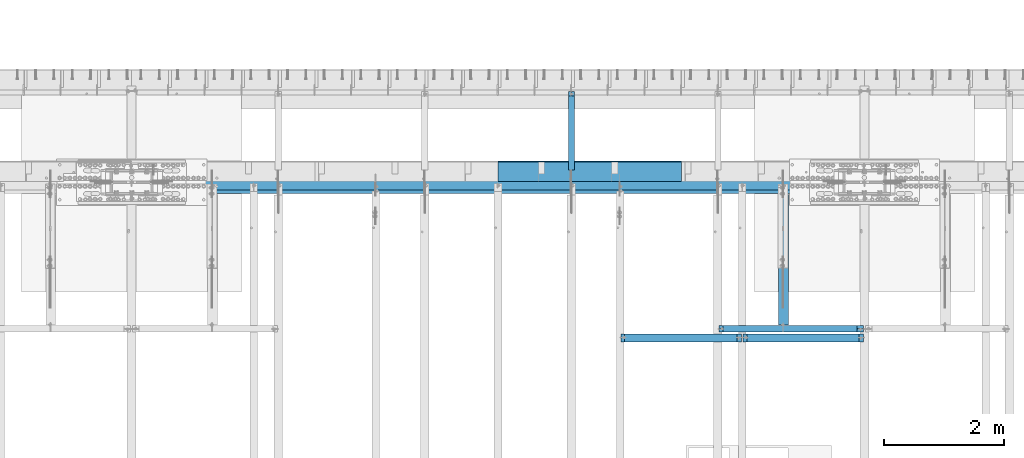
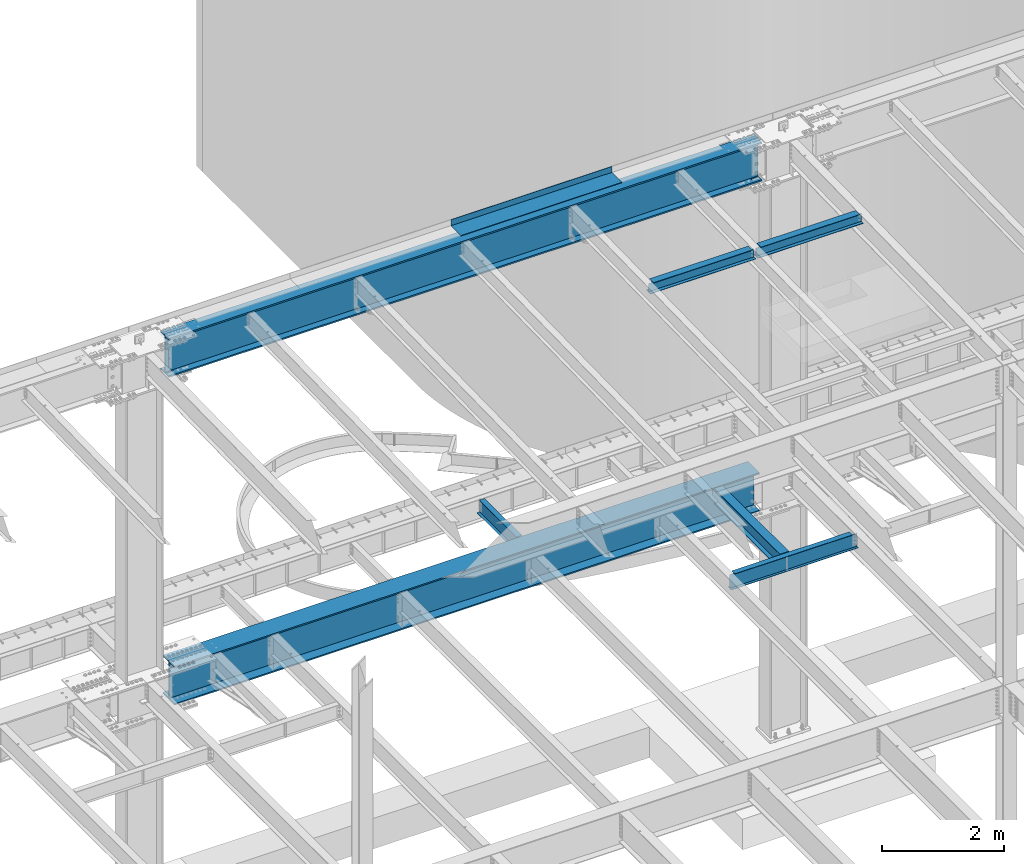
# One storey, part 1135 of 1763: 8 beams, 7 elements without a shape of their own.
"""IFC2X3 building model written with IfcOpenShell, lengths in millimetres."""

from ifc_helpers import new_model, si_unit, frame, origin_with_axes, place, context, subcontext, project, spatial, faceted_brep, material, type_object, element, aggregate, save


model = new_model("IFC2X3")

# Units and contexts
model_context = context("Model", 3, precision=1e-05, world=origin_with_axes())
body_context = subcontext(model_context, "Body", "Model", "MODEL_VIEW")
ifc_project = project(units=[si_unit("LENGTHUNIT", "METRE", prefix="MILLI"), si_unit("AREAUNIT", "SQUARE_METRE"), si_unit("VOLUMEUNIT", "CUBIC_METRE"), si_unit("MASSUNIT", "GRAM", prefix="KILO"), si_unit("TIMEUNIT", "SECOND"), si_unit("PLANEANGLEUNIT", "RADIAN"), si_unit("SOLIDANGLEUNIT", "STERADIAN"), si_unit("THERMODYNAMICTEMPERATUREUNIT", "DEGREE_CELSIUS"), si_unit("LUMINOUSINTENSITYUNIT", "LUMEN")], contexts=[model_context])

# Site, building, storey
site_placement = place(None, origin_with_axes())
site = spatial("IfcSite", under=ifc_project, at=site_placement, CompositionType="ELEMENT")
building_placement = place(site_placement, origin_with_axes())
building = spatial("IfcBuilding", under=site, at=building_placement, Name="Undefined", CompositionType="ELEMENT")
storey_placement = place(building_placement, origin_with_axes())
storey = spatial("IfcBuildingStorey", under=building, at=storey_placement, Name="Undefined", CompositionType="ELEMENT", Elevation=0.0)

# Assembly, beam
assembly_1_placement = place(storey_placement, origin_with_axes())
assembly_1 = element("IfcElementAssembly", 1, at=assembly_1_placement, inside=storey, Name="BEAM", AssemblyPlace="NOTDEFINED", PredefinedType="RIGID_FRAME")
ifc_material_1 = material(Name="STEEL/A992")
beam_type_1 = type_object("IfcBeamType", Name="W8X18", PredefinedType="NOTDEFINED")
beam_1_placement = place(assembly_1_placement, frame((-53466.5223188412, 49529.603125, 11592.1111170495), z_axis=(0.0, 0.0, 1.0), x_axis=(1.0, 0.0, 0.0)))
beam_1 = element("IfcBeam", 2, at=beam_1_placement, type_object=beam_type_1, material=ifc_material_1, Name="BEAM", ObjectType="W8X18", context=body_context, shape_type="Brep", body=[
    faceted_brep([(1947.72688668019, -3.17500000383734, 68.5472454981009), (1947.7268866802, 3.1749999961612, 68.5472454981009), (1946.86590192084, 3.17499999616848, 69.8358002505338), (1946.86590177228, -3.17500000383006, 69.8358004728379), (1951.84706314834, -3.17500000384462, 65.7942315976234), (1951.84706314836, 3.17499999615393, 65.7942315976234), (1956.70714266639, -3.17500000385189, 64.8275016750358), (1956.7071426664, 3.17499999614665, 64.8275016750358), (2015.44464294919, -3.17500000397558, 64.8275016750358), (2015.44464276504, 3.17499999602296, 64.8275016750358), (1946.13938981476, -3.17500000383006, 70.3212402430472), (1946.13938963061, 3.17499999616848, 70.3212402430472), (1943.38637573014, 3.17499999617576, 74.4414167112009), (1943.38637591428, -3.17500000383006, 74.4414167112009), (1942.41964580755, 3.17499999617576, 79.3014962292473), (1942.41964599169, -3.17500000382279, 79.3014962292473), (76.1999968561649, 3.17499999984284, 95.25), (76.1999950146637, 66.6749999998428, 95.25), (1942.41964396604, 66.6749999961758, 95.25), (1942.41964580755, 3.17499999617576, 95.25), (76.1999988818134, -66.6750000001557, 103.1875), (76.1999988818134, -66.6750000001557, 95.25), (1942.41964783319, -66.6750000038228, 95.25), (1942.41964783319, -66.6750000038228, 103.1875), (76.1999950146637, 66.6749999998428, 103.1875), (1942.41964396604, 66.6749999961758, 103.1875), (1942.41964599169, -3.17500000382279, 95.25), (76.1999970403122, -3.17500000015571, 95.25), (76.1999968561649, 3.17499999984284, 79.3014961863064), (76.1999970403122, -3.17500000015571, 79.3014961863064), (75.2332669335738, 3.17499999985012, 74.44141666826), (75.233267117721, -3.17500000014843, 74.44141666826), (72.4802530330999, 3.17499999985012, 70.3212402001063), (72.4802532172471, -3.17500000014843, 70.3212402001063), (71.7537410457226, 3.17499999985739, 69.83580040995), (71.7537408971693, -3.17500000014115, 69.8358001876459), (70.8927561769378, 3.17499999985739, 68.5472454937626), (70.8927561769233, -3.17500000014115, 68.5472454937626), (66.7725797087842, 3.17499999986467, 65.7942315932851), (66.7725797087696, -3.17500000013388, 65.7942315932851), (61.912500190745, 3.17499999987194, 64.8275016706975), (61.9125001907232, -3.1750000001266, 64.8275016706975), (15.8749999079228, 3.17499999996653, 64.8275016706975), (15.87500009207, -3.17500000003201, 64.8275016706975), (15.8749999079228, 3.17499999996653, -95.25), (15.8749980664215, 66.6749999999665, -95.25), (15.8749980664215, 66.6749999999665, -103.1875), (15.8750019335712, -66.675000000032, -103.1875), (15.8750019335712, -66.675000000032, -95.25), (15.87500009207, -3.17500000003201, -95.25), (2015.44464276504, 3.17499999602296, -95.25), (2015.44464092355, 66.674999996023, -95.25), (2015.44464092355, 66.674999996023, -103.1875), (2015.4446447907, -66.6750000039756, -103.1875), (2015.4446447907, -66.6750000039756, -95.25), (2015.44464294919, -3.17500000397558, -95.25)], [[[0, 1, 2, 3]], [[4, 5, 1, 0]], [[6, 7, 5, 4]], [[8, 9, 7, 6]], [[10, 11, 12, 13]], [[13, 12, 14, 15]], [[16, 17, 18, 19]], [[20, 21, 22, 23]], [[24, 20, 23, 25]], [[17, 24, 25, 18]], [[23, 22, 26, 15, 14, 19, 18, 25]], [[21, 27, 26, 22]], [[20, 24, 17, 16, 28, 29, 27, 21]], [[29, 28, 30, 31]], [[31, 30, 32, 33]], [[33, 32, 34, 35]], [[35, 34, 36, 37]], [[37, 36, 38, 39]], [[39, 38, 40, 41]], [[41, 40, 42, 43]], [[44, 45, 46, 47, 48, 49, 43, 42]], [[45, 44, 50, 51]], [[46, 45, 51, 52]], [[47, 46, 52, 53]], [[48, 47, 53, 54]], [[49, 48, 54, 55]], [[4, 0, 3, 10, 13, 15, 26, 27, 29, 31, 33, 35, 37, 39, 41, 43, 49, 55, 8, 6]], [[11, 10, 3, 2]], [[50, 44, 42, 40, 38, 36, 34, 32, 30, 28, 16, 19, 14, 12, 11, 2, 1, 5, 7, 9]], [[55, 54, 53, 52, 51, 50, 9, 8]]]),
])
aggregate(assembly_1, [beam_1])

assembly_2_placement = place(storey_placement, origin_with_axes())
assembly_2 = element("IfcElementAssembly", 3, at=assembly_2_placement, inside=storey, Name="BEAM", AssemblyPlace="NOTDEFINED", PredefinedType="RIGID_FRAME")
beam_2_placement = place(assembly_2_placement, frame((-51434.5223188412, 49529.603125, 11592.1111170495), z_axis=(0.0, 0.0, 1.0), x_axis=(1.0, 0.0, 0.0)))
beam_2 = element("IfcBeam", 4, at=beam_2_placement, type_object=beam_type_1, material=ifc_material_1, Name="BEAM", ObjectType="W8X18", context=body_context, shape_type="Brep", body=[
    faceted_brep([(1947.72688668019, -3.17500000383734, 68.5472454981009), (1947.7268866802, 3.1749999961612, 68.5472454981009), (1946.86590192084, 3.17499999616848, 69.8358002505338), (1946.86590177228, -3.17500000383006, 69.8358004728379), (1951.84706314834, -3.17500000384462, 65.7942315976234), (1951.84706314836, 3.17499999615393, 65.7942315976234), (1956.70714266639, -3.17500000385189, 64.8275016750358), (1956.7071426664, 3.17499999614665, 64.8275016750358), (2015.44464294919, -3.17500000397558, 64.8275016750358), (2015.44464276504, 3.17499999602296, 64.8275016750358), (1946.13938981476, -3.17500000383006, 70.3212402430472), (1946.13938963061, 3.17499999616848, 70.3212402430472), (1943.38637573014, 3.17499999617576, 74.4414167112009), (1943.38637591428, -3.17500000383006, 74.4414167112009), (1942.41964580755, 3.17499999617576, 79.3014962292473), (1942.41964599169, -3.17500000382279, 79.3014962292473), (76.1999968561649, 3.17499999984284, 95.25), (76.1999950146637, 66.6749999998428, 95.25), (1942.41964396604, 66.6749999961758, 95.25), (1942.41964580755, 3.17499999617576, 95.25), (76.1999988818134, -66.6750000001557, 103.1875), (76.1999988818134, -66.6750000001557, 95.25), (1942.41964783319, -66.6750000038228, 95.25), (1942.41964783319, -66.6750000038228, 103.1875), (76.1999950146637, 66.6749999998428, 103.1875), (1942.41964396604, 66.6749999961758, 103.1875), (1942.41964599169, -3.17500000382279, 95.25), (76.1999970403122, -3.17500000015571, 95.25), (76.1999968561649, 3.17499999984284, 79.3014961863064), (76.1999970403122, -3.17500000015571, 79.3014961863064), (75.2332669335738, 3.17499999985012, 74.44141666826), (75.233267117721, -3.17500000014843, 74.44141666826), (72.4802530330999, 3.17499999985012, 70.3212402001063), (72.4802532172471, -3.17500000014843, 70.3212402001063), (71.7537410457226, 3.17499999985739, 69.83580040995), (71.7537408971693, -3.17500000014115, 69.8358001876459), (70.8927561769378, 3.17499999985739, 68.5472454937626), (70.8927561769233, -3.17500000014115, 68.5472454937626), (66.7725797087842, 3.17499999986467, 65.7942315932851), (66.7725797087696, -3.17500000013388, 65.7942315932851), (61.912500190745, 3.17499999987194, 64.8275016706975), (61.9125001907232, -3.1750000001266, 64.8275016706975), (15.8749999079228, 3.17499999996653, 64.8275016706975), (15.87500009207, -3.17500000003201, 64.8275016706975), (15.8749999079228, 3.17499999996653, -95.25), (15.8749980664215, 66.6749999999665, -95.25), (15.8749980664215, 66.6749999999665, -103.1875), (15.8750019335712, -66.675000000032, -103.1875), (15.8750019335712, -66.675000000032, -95.25), (15.87500009207, -3.17500000003201, -95.25), (2015.44464276504, 3.17499999602296, -95.25), (2015.44464092355, 66.674999996023, -95.25), (2015.44464092355, 66.674999996023, -103.1875), (2015.4446447907, -66.6750000039756, -103.1875), (2015.4446447907, -66.6750000039756, -95.25), (2015.44464294919, -3.17500000397558, -95.25)], [[[0, 1, 2, 3]], [[4, 5, 1, 0]], [[6, 7, 5, 4]], [[8, 9, 7, 6]], [[10, 11, 12, 13]], [[13, 12, 14, 15]], [[16, 17, 18, 19]], [[20, 21, 22, 23]], [[24, 20, 23, 25]], [[17, 24, 25, 18]], [[23, 22, 26, 15, 14, 19, 18, 25]], [[21, 27, 26, 22]], [[20, 24, 17, 16, 28, 29, 27, 21]], [[29, 28, 30, 31]], [[31, 30, 32, 33]], [[33, 32, 34, 35]], [[35, 34, 36, 37]], [[37, 36, 38, 39]], [[39, 38, 40, 41]], [[41, 40, 42, 43]], [[44, 45, 46, 47, 48, 49, 43, 42]], [[45, 44, 50, 51]], [[46, 45, 51, 52]], [[47, 46, 52, 53]], [[48, 47, 53, 54]], [[49, 48, 54, 55]], [[4, 0, 3, 10, 13, 15, 26, 27, 29, 31, 33, 35, 37, 39, 41, 43, 49, 55, 8, 6]], [[11, 10, 3, 2]], [[50, 44, 42, 40, 38, 36, 34, 32, 30, 28, 16, 19, 14, 12, 11, 2, 1, 5, 7, 9]], [[55, 54, 53, 52, 51, 50, 9, 8]]]),
])
aggregate(assembly_2, [beam_2])

assembly_3_placement = place(storey_placement, origin_with_axes())
assembly_3 = element("IfcElementAssembly", 5, at=assembly_3_placement, inside=storey, Name="BEAM", AssemblyPlace="NOTDEFINED", PredefinedType="RIGID_FRAME")
ifc_material_2 = material(Name="STEEL/A36")
beam_type_2 = type_object("IfcBeamType", PredefinedType="NOTDEFINED")
beam_3_placement = place(assembly_3_placement, frame((-53971.2617736983, 52133.5000002128, 11752.2624917654), z_axis=(-1.0, 0.0, 0.0), x_axis=(0.0, 1.0, 0.0)))
beam_3 = element("IfcBeam", 6, at=beam_3_placement, type_object=beam_type_2, material=ifc_material_2, Name="BENT_PLATE", context=body_context, shape_type="Brep", body=[
    faceted_brep([(0.0, -4.76249999999982, -1524.0), (0.0, -4.76249999999982, 1524.0), (0.0, 4.76249999999982, 1524.0), (0.0, 4.76249999999982, -1524.0), (336.549987792969, 4.76250000000073, 1524.0), (336.549987792969, 4.76250000000073, -1524.0), (327.024987792975, -4.76250000000073, -1524.0), (327.024987792967, -4.76250000000073, 1524.00000000001), (336.549987792969, -122.237499999999, 1524.0), (336.549987792969, -122.237499999999, -1524.0), (327.024987792975, -122.237499999999, 1524.0), (327.024987792975, -122.237499999999, -1524.0)], [[[0, 1, 2, 3]], [[3, 2, 4, 5]], [[1, 0, 6, 7]], [[5, 4, 8, 9]], [[4, 2, 1, 7, 10, 8]], [[7, 6, 11, 10]], [[6, 0, 3, 5, 9, 11]], [[10, 11, 9, 8]]]),
])

assembly_4_placement = place(storey_placement, origin_with_axes())
assembly_4 = element("IfcElementAssembly", 7, at=assembly_4_placement, inside=storey, Name="BEAM", AssemblyPlace="NOTDEFINED", PredefinedType="RIGID_FRAME")
beam_type_3 = type_object("IfcBeamType", Name="W12X16", PredefinedType="NOTDEFINED")
beam_4_placement = place(assembly_4_placement, frame((-54279.2372736983, 52120.8, 5041.9), z_axis=(0.0, 0.0, 1.0), x_axis=(0.0, 1.0, 0.0)))
beam_4 = element("IfcBeam", 8, at=beam_4_placement, type_object=beam_type_3, material=ifc_material_1, Name="BEAM", ObjectType="W12X16", context=body_context, shape_type="Brep", body=[
    faceted_brep([(20.6374999999971, -3.17500000000291, -114.3), (20.6374999999971, 3.17500000000291, -114.3), (192.087500190733, 3.17500000000291, -114.3), (192.087500190733, -3.17500000000291, -114.3), (196.94757970878, 3.17500000000291, -115.266729922588), (196.94757970878, -3.17500000000291, -115.266729922588), (201.067756176933, 3.17500000000291, -118.019743823066), (201.067756176933, -3.17500000000291, -118.019743823066), (203.820770077407, 3.17500000000291, -122.13992029122), (203.820770077407, -3.17500000000291, -122.13992029122), (204.787499999999, -3.17500000000291, -126.999999809265), (204.787499999999, 3.17500000000291, -126.999999809265), (204.787499999999, 3.17500000000291, -146.05), (204.787499999999, 50.8000000000029, -146.05), (204.787499999999, 50.8000000000029, -152.4), (204.787499999999, -50.8000000000029, -152.4), (204.787499999999, -50.8000000000029, -146.05), (204.787499999999, -3.17500000000291, -146.05), (1431.13125000001, 50.8000000000029, 146.05), (1431.13125000001, 3.17500000000291, 146.05), (204.787499999999, 3.17500000000291, 146.05), (204.787499999999, 50.8000000000029, 146.05), (192.087500190733, -3.17500000000291, 114.3), (192.087500190733, 3.17500000000291, 114.3), (20.6374999999971, 3.17500000000291, 114.3), (20.6374999999971, -3.17500000000291, 114.3), (196.94757970878, -3.17500000000291, 115.266729922588), (196.94757970878, 3.17500000000291, 115.266729922588), (201.067756176933, -3.17500000000291, 118.019743823066), (201.067756176933, 3.17500000000291, 118.019743823066), (203.820770077407, -3.17500000000291, 122.13992029122), (203.820770077407, 3.17500000000291, 122.13992029122), (204.787499999999, -3.17500000000291, 126.999999809265), (204.787499999999, 3.17500000000291, 126.999999809265), (1431.13125000001, -50.8000000000029, 152.4), (1431.13125000001, 50.8000000000029, 152.4), (204.787499999999, 50.8000000000029, 152.4), (204.787499999999, -50.8000000000029, 152.4), (1431.13125000001, -50.8000000000029, 146.05), (204.787499999999, -50.8000000000029, 146.05), (1431.13125000001, -3.17500000000291, 146.05), (204.787499999999, -3.17500000000291, 146.05), (1431.13125000001, -3.17500000000291, 139.440001487732), (1431.13125000001, 3.17500000000291, 139.440001487732), (1432.0979799226, -3.17500000000291, 134.579921969686), (1432.0979799226, 3.17500000000291, 134.579921969686), (1434.85099382307, -3.17500000000291, 130.459745501533), (1434.85099382307, 3.17500000000291, 130.459745501533), (1438.97117029122, -3.17500000000291, 127.706731601054), (1438.97117029122, 3.17500000000291, 127.706731601054), (1443.83124980927, -3.17500000000291, 126.740001678467), (1443.83124980927, 3.17500000000291, 126.740001678467), (1507.33125, -3.17500000000291, 126.740001678467), (1507.33125, 3.17500000000291, 126.740001678467), (1507.33125, -3.17500000000291, -146.05), (1507.33125, -50.8000000000029, -146.05), (1507.33125, -50.8000000000029, -152.4), (1507.33125, 50.8000000000029, -152.4), (1507.33125, 50.8000000000029, -146.05), (1507.33125, 3.17500000000291, -146.05)], [[[0, 1, 2, 3]], [[3, 2, 4, 5]], [[5, 4, 6, 7]], [[7, 6, 8, 9]], [[10, 11, 12, 13, 14, 15, 16, 17]], [[9, 8, 11, 10]], [[18, 19, 20, 21]], [[22, 23, 24, 25]], [[26, 27, 23, 22]], [[28, 29, 27, 26]], [[30, 31, 29, 28]], [[32, 33, 31, 30]], [[34, 35, 36, 37]], [[38, 34, 37, 39]], [[40, 38, 39, 41]], [[37, 36, 21, 20, 33, 32, 41, 39]], [[35, 18, 21, 36]], [[34, 38, 40, 42, 43, 19, 18, 35]], [[44, 45, 43, 42]], [[46, 47, 45, 44]], [[48, 49, 47, 46]], [[50, 51, 49, 48]], [[52, 53, 51, 50]], [[54, 55, 56, 57, 58, 59, 53, 52]], [[55, 54, 17, 16]], [[56, 55, 16, 15]], [[57, 56, 15, 14]], [[58, 57, 14, 13]], [[59, 58, 13, 12]], [[6, 4, 2, 1, 24, 23, 27, 29, 31, 33, 20, 19, 43, 45, 47, 49, 51, 53, 59, 12, 11, 8]], [[25, 24, 1, 0]], [[54, 52, 50, 48, 46, 44, 42, 40, 41, 32, 30, 28, 26, 22, 25, 0, 3, 5, 7, 9, 10, 17]]]),
])
aggregate(assembly_4, [beam_4])

assembly_5_placement = place(storey_placement, origin_with_axes())
assembly_5 = element("IfcElementAssembly", 9, at=assembly_5_placement, inside=storey, Name="BEAM", AssemblyPlace="NOTDEFINED", PredefinedType="RIGID_FRAME")
beam_type_4 = type_object("IfcBeamType", Name="W12X26", PredefinedType="NOTDEFINED")
beam_5_placement = place(assembly_5_placement, frame((-50748.6372736983, 49682.4, 5038.725), z_axis=(0.0, 0.0, 1.0), x_axis=(0.0, 1.0, 0.0)))
beam_5 = element("IfcBeam", 10, at=beam_5_placement, type_object=beam_type_4, material=ifc_material_1, Name="BEAM", ObjectType="W12X26", context=body_context, shape_type="Brep", body=[
    faceted_brep([(2233.6125, -3.17500000000291, -146.05), (2233.6125, -82.5500000000029, -146.05), (2233.6125, -82.5500000000029, -155.575), (2233.6125, 82.5500000000029, -155.575), (2233.6125, 82.5500000000029, -146.05), (2233.6125, 3.17500000000291, -146.05), (2233.6125, 3.17500000000291, -123.824999809265), (2233.6125, -3.17500000000291, -123.824999809265), (2234.57922992259, 3.17500000000291, -118.96492029122), (2234.57922992259, -3.17500000000291, -118.96492029122), (2237.33224382307, 3.17500000000291, -114.844743823066), (2237.33224382307, -3.17500000000291, -114.844743823066), (2241.45242029122, 3.17500000000291, -112.091729922588), (2241.45242029122, -3.17500000000291, -112.091729922588), (2246.31249980927, 3.17500000000291, -111.125), (2246.31249980927, -3.17500000000291, -111.125), (2417.7625, -3.17500000000291, -111.125), (2417.7625, 3.17500000000291, -111.125), (65.8812499999913, 3.17500000000291, 146.05), (65.8812499999913, 82.5500000000029, 146.05), (2233.6125, 82.5500000000029, 146.05), (2233.6125, 3.17500000000291, 146.05), (65.8812499999913, -3.17500000000291, -123.824999809265), (65.8812499999913, 3.17500000000291, -123.824999809265), (65.8812499999913, 3.17500000000291, -146.05), (65.8812499999913, 82.5500000000029, -146.05), (65.8812499999913, 82.5500000000029, -155.575), (65.8812499999913, -82.5500000000029, -155.575), (65.8812499999913, -82.5500000000029, -146.05), (65.8812499999913, -3.17500000000291, -146.05), (64.9145200774001, -3.17500000000291, -118.96492029122), (64.9145200774001, 3.17500000000291, -118.96492029122), (62.1615061769262, -3.17500000000291, -114.844743823066), (62.1615061769262, 3.17500000000291, -114.844743823066), (58.0413297087725, -3.17500000000291, -112.091729922588), (58.0413297087725, 3.17500000000291, -112.091729922588), (53.1812501907261, -3.17500000000291, -111.125), (53.1812501907261, 3.17500000000291, -111.125), (15.0812499999956, -3.17500000000291, -111.125), (15.0812499999956, 3.17500000000291, -111.125), (15.0812499999956, -3.17500000000291, 117.475), (15.0812499999956, 3.17500000000291, 117.475), (53.1812501907261, -3.17500000000291, 117.475), (53.1812501907261, 3.17500000000291, 117.475), (58.0413297087725, -3.17500000000291, 118.441729922588), (58.0413297087725, 3.17500000000291, 118.441729922588), (62.1615061769262, -3.17500000000291, 121.194743823066), (62.1615061769262, 3.17500000000291, 121.194743823066), (64.9145200774001, -3.17500000000291, 125.31492029122), (64.9145200774001, 3.17500000000291, 125.31492029122), (65.8812499999913, -3.17500000000291, 130.174999809266), (65.8812499999913, 3.17500000000291, 130.174999809266), (65.8812499999913, -82.5500000000029, 155.575), (65.8812499999913, 82.5500000000029, 155.575), (65.8812499999913, -3.17500000000291, 146.05), (65.8812499999913, -82.5500000000029, 146.05), (2233.6125, -3.17500000000291, 146.05), (2233.6125, -82.5500000000029, 146.05), (2233.6125, -82.5500000000029, 155.575), (2233.6125, 82.5500000000029, 155.575), (2233.6125, -3.17500000000291, 123.824999809265), (2233.6125, 3.17500000000291, 123.824999809265), (2234.57922992259, -3.17500000000291, 118.96492029122), (2234.57922992259, 3.17500000000291, 118.96492029122), (2237.33224382307, -3.17500000000291, 114.844743823066), (2237.33224382307, 3.17500000000291, 114.844743823066), (2241.45242029122, -3.17500000000291, 112.091729922588), (2241.45242029122, 3.17500000000291, 112.091729922588), (2246.31249980927, -3.17500000000291, 111.125), (2246.31249980927, 3.17500000000291, 111.125), (2417.7625, -3.17500000000291, 111.125), (2417.7625, 3.17500000000291, 111.125)], [[[0, 1, 2, 3, 4, 5, 6, 7]], [[7, 6, 8, 9]], [[9, 8, 10, 11]], [[11, 10, 12, 13]], [[13, 12, 14, 15]], [[16, 15, 14, 17]], [[18, 19, 20, 21]], [[22, 23, 24, 25, 26, 27, 28, 29]], [[30, 31, 23, 22]], [[32, 33, 31, 30]], [[34, 35, 33, 32]], [[36, 37, 35, 34]], [[38, 39, 37, 36]], [[40, 41, 39, 38]], [[42, 43, 41, 40]], [[44, 45, 43, 42]], [[46, 47, 45, 44]], [[48, 49, 47, 46]], [[50, 51, 49, 48]], [[52, 53, 19, 18, 51, 50, 54, 55]], [[55, 54, 56, 57]], [[52, 55, 57, 58]], [[53, 52, 58, 59]], [[19, 53, 59, 20]], [[58, 57, 56, 60, 61, 21, 20, 59]], [[62, 63, 61, 60]], [[64, 65, 63, 62]], [[66, 67, 65, 64]], [[68, 69, 67, 66]], [[70, 71, 69, 68]], [[71, 70, 16, 17]], [[12, 10, 8, 6, 5, 24, 23, 31, 33, 35, 37, 39, 41, 43, 45, 47, 49, 51, 18, 21, 61, 63, 65, 67, 69, 71, 17, 14]], [[25, 24, 5, 4]], [[26, 25, 4, 3]], [[27, 26, 3, 2]], [[28, 27, 2, 1]], [[29, 28, 1, 0]], [[70, 68, 66, 64, 62, 60, 56, 54, 50, 48, 46, 44, 42, 40, 38, 36, 34, 32, 30, 22, 29, 0, 7, 9, 11, 13, 15, 16]]]),
])
aggregate(assembly_5, [beam_5])

assembly_6_placement = place(storey_placement, origin_with_axes())
assembly_6 = element("IfcElementAssembly", 11, at=assembly_6_placement, inside=storey, Name="BEAM", AssemblyPlace="NOTDEFINED", PredefinedType="RIGID_FRAME")
beam_type_5 = type_object("IfcBeamType", Name="W12X14", PredefinedType="NOTDEFINED")
beam_6_placement = place(assembly_6_placement, frame((-51840.8372736983, 49682.4, 5043.4875), z_axis=(0.0, 0.0, 1.0), x_axis=(1.0, 0.0, 0.0)))
beam_6 = element("IfcBeam", 12, at=beam_6_placement, type_object=beam_type_5, material=ifc_material_1, Name="BEAM", ObjectType="W12X14", context=body_context, shape_type="Brep", body=[
    faceted_brep([(2313.78125, -50.8000000000029, 150.8125), (2313.78125, -50.8000000000029, 144.4625), (2313.78125, -2.38124999999854, 144.4625), (2313.78125, -2.38124999999854, 131.502501487732), (2313.78125, 2.38124999999854, 131.502501487732), (2313.78125, 2.38124999999854, 144.4625), (2313.78125, 50.8000000000029, 144.4625), (2313.78125, 50.8000000000029, 150.8125), (2314.74797992259, -2.38124999999854, 126.642421969686), (2314.74797992259, 2.38124999999854, 126.642421969686), (2317.50099382307, -2.38124999999854, 122.522245501533), (2317.50099382307, 2.38124999999854, 122.522245501533), (2321.62117029122, -2.38124999999854, 119.769231601054), (2321.62117029122, 2.38124999999854, 119.769231601054), (2326.48124980927, -2.38124999999854, 118.802501678467), (2326.48124980927, 2.38124999999854, 118.802501678467), (2421.73125, -2.38124999999854, 118.802501678467), (2421.73125, 2.38124999999854, 118.802501678467), (85.724999999984, -50.8000000000029, 150.8125), (85.724999999984, 50.8000000000029, 150.8125), (85.724999999984, 50.8000000000029, 144.4625), (85.724999999984, 2.38124999999854, 144.4625), (85.724999999984, 2.38124999999854, 137.852501487731), (85.724999999984, -2.38124999999854, 137.852501487731), (85.724999999984, -2.38124999999854, 144.4625), (85.724999999984, -50.8000000000029, 144.4625), (84.7582700773928, 2.38124999999854, 132.992421969686), (84.7582700773928, -2.38124999999854, 132.992421969686), (82.0052561769189, 2.38124999999854, 128.872245501532), (82.0052561769189, -2.38124999999854, 128.872245501532), (77.8850797087653, 2.38124999999854, 126.119231601054), (77.8850797087653, -2.38124999999854, 126.119231601054), (73.0250001907189, 2.38124999999854, 125.152501678466), (73.0250001907189, -2.38124999999854, 125.152501678466), (15.875, 2.38124999999854, 125.152501678466), (15.875, -2.38124999999854, 125.152501678466), (15.875, 2.38124999999854, -144.4625), (15.875, 50.8000000000029, -144.4625), (15.875, 50.8000000000029, -150.8125), (15.875, -50.8000000000029, -150.8125), (15.875, -50.8000000000029, -144.4625), (15.875, -2.38124999999854, -144.4625), (2421.73125, 2.38124999999854, -144.4625), (2421.73125, 50.8000000000029, -144.4625), (2421.73125, 50.8000000000029, -150.8125), (2421.73125, -50.8000000000029, -150.8125), (2421.73125, -50.8000000000029, -144.4625), (2421.73125, -2.38124999999854, -144.4625)], [[[0, 1, 2, 3, 4, 5, 6, 7]], [[8, 9, 4, 3]], [[10, 11, 9, 8]], [[12, 13, 11, 10]], [[14, 15, 13, 12]], [[16, 17, 15, 14]], [[18, 19, 20, 21, 22, 23, 24, 25]], [[23, 22, 26, 27]], [[27, 26, 28, 29]], [[29, 28, 30, 31]], [[31, 30, 32, 33]], [[33, 32, 34, 35]], [[36, 37, 38, 39, 40, 41, 35, 34]], [[37, 36, 42, 43]], [[38, 37, 43, 44]], [[39, 38, 44, 45]], [[40, 39, 45, 46]], [[41, 40, 46, 47]], [[12, 10, 8, 3, 2, 24, 23, 27, 29, 31, 33, 35, 41, 47, 16, 14]], [[25, 24, 2, 1]], [[18, 25, 1, 0]], [[19, 18, 0, 7]], [[20, 19, 7, 6]], [[21, 20, 6, 5]], [[42, 36, 34, 32, 30, 28, 26, 22, 21, 5, 4, 9, 11, 13, 15, 17]], [[47, 46, 45, 44, 43, 42, 17, 16]]]),
])
aggregate(assembly_6, [beam_6])

assembly_7_placement = place(storey_placement, origin_with_axes())
assembly_7 = element("IfcElementAssembly", 13, at=assembly_7_placement, inside=storey, Name="BEAM", AssemblyPlace="NOTDEFINED", PredefinedType="RIGID_FRAME")
beam_type_6 = type_object("IfcBeamType", Name="W30X173", PredefinedType="NOTDEFINED")
beam_7_placement = place(assembly_7_placement, frame((-61594.4372736983, 52120.8, 4806.95), z_axis=(0.0, 0.0, 1.0), x_axis=(1.0, 0.0, 0.0)))
beam_7 = element("IfcBeam", 14, at=beam_7_placement, type_object=beam_type_6, material=ifc_material_1, Name="BEAM", ObjectType="W30X173", context=body_context, shape_type="Brep", body=[
    faceted_brep([(11634.7875, 41.2750003814726, -360.3625), (11496.6750001907, 41.2750003814726, -360.3625), (11496.6750001907, 41.2750003814726, -387.35), (11634.7875, 41.2750003814726, -387.35), (11492.4224304756, 40.4291116719833, -360.3625), (11492.4224304756, 40.4291116719833, -387.35), (11488.8172759499, 38.0202244315442, -360.3625), (11488.8172759499, 38.0202244315442, -387.35), (11486.4083887095, 34.4150699058882, -360.3625), (11486.4083887095, 34.4150699058882, -387.35), (11485.5625, 30.1625001907378, -360.3625), (11485.5625, 30.1625001907378, -387.35), (11486.4083887095, 25.9099304755873, -360.3625), (11486.4083887095, 25.9099304755873, -387.35), (11488.8172759499, 22.3047759499314, -360.3625), (11488.8172759499, 22.3047759499314, -387.35), (11492.4224304756, 19.8958887094923, -360.3625), (11492.4224304756, 19.8958887094923, -387.35), (11496.6750001907, 19.0500000000029, -360.3625), (11496.6750001907, 19.0500000000029, -387.35), (11634.7875, 19.0500000000029, -360.3625), (11634.7875, 19.0500000000029, -387.35), (557.212499999994, 190.5, -387.35), (557.212499999994, 190.5, -360.3625), (11634.7875, 190.5, -360.3625), (11634.7875, 190.5, -387.35), (557.212499999994, 41.2750003814726, -387.35), (557.212499999994, 41.2750003814726, -360.3625), (695.324999809258, 41.2750003814726, -387.35), (695.324999809258, 41.2750003814726, -360.3625), (699.577569524408, 40.4291116719833, -387.35), (699.577569524408, 40.4291116719833, -360.3625), (703.182724050064, 38.0202244315442, -387.35), (703.182724050064, 38.0202244315442, -360.3625), (705.591611290503, 34.4150699058882, -387.35), (705.591611290503, 34.4150699058882, -360.3625), (706.437499999993, 30.1625001907378, -387.35), (706.437499999993, 30.1625001907378, -360.3625), (705.591611290503, 25.9099304755873, -387.35), (705.591611290503, 25.9099304755873, -360.3625), (703.182724050064, 22.3047759499314, -387.35), (703.182724050064, 22.3047759499314, -360.3625), (699.577569524408, 19.8958887094923, -387.35), (699.577569524408, 19.8958887094923, -360.3625), (695.324999809258, 19.0500000000029, -387.35), (695.324999809258, 19.0500000000029, -360.3625), (557.212499999994, 19.0500000000029, -387.35), (557.212499999994, 19.0500000000029, -360.3625), (557.212499999994, -190.5, -387.35), (557.212499999994, -190.5, -360.3625), (557.212499999994, -7.9375, -360.3625), (557.212499999994, -7.9375, 360.3625), (557.212499999994, -190.5, 360.3625), (557.212499999994, -190.5, 387.35), (557.212499999994, 190.5, 387.35), (557.212499999994, 190.5, 360.3625), (557.212499999994, 7.9375, 360.3625), (557.212499999994, 7.9375, -360.3625), (11634.7875, -190.5, -387.35), (11634.7875, -190.5, -360.3625), (11634.7875, -7.9375, -360.3625), (11634.7875, -7.9375, 360.3625), (11634.7875, -190.5, 360.3625), (11634.7875, -190.5, 387.35), (11634.7875, 190.5, 387.35), (11634.7875, 190.5, 360.3625), (11634.7875, 7.9375, 360.3625), (11634.7875, 7.9375, -360.3625)], [[[0, 1, 2, 3]], [[4, 5, 2, 1]], [[6, 7, 5, 4]], [[8, 9, 7, 6]], [[10, 11, 9, 8]], [[12, 13, 11, 10]], [[14, 15, 13, 12]], [[16, 17, 15, 14]], [[18, 19, 17, 16]], [[20, 21, 19, 18]], [[22, 23, 24, 25]], [[23, 22, 26, 27]], [[27, 26, 28, 29]], [[29, 28, 30, 31]], [[31, 30, 32, 33]], [[33, 32, 34, 35]], [[35, 34, 36, 37]], [[37, 36, 38, 39]], [[39, 38, 40, 41]], [[41, 40, 42, 43]], [[43, 42, 44, 45]], [[45, 44, 46, 47]], [[48, 49, 50, 51, 52, 53, 54, 55, 56, 57, 47, 46]], [[49, 48, 58, 59]], [[50, 49, 59, 60]], [[51, 50, 60, 61]], [[52, 51, 61, 62]], [[53, 52, 62, 63]], [[54, 53, 63, 64]], [[55, 54, 64, 65]], [[56, 55, 65, 66]], [[57, 56, 66, 67]], [[16, 14, 12, 10, 8, 6, 4, 1, 0, 24, 23, 27, 29, 31, 33, 35, 37, 39, 41, 43, 45, 47, 57, 67, 20, 18]], [[25, 24, 0, 3]], [[58, 48, 46, 44, 42, 40, 38, 36, 34, 32, 30, 28, 26, 22, 25, 3, 2, 5, 7, 9, 11, 13, 15, 17, 19, 21]], [[67, 66, 65, 64, 63, 62, 61, 60, 59, 58, 21, 20]]]),
])
aggregate(assembly_7, [beam_7])

# Beam
beam_type_7 = type_object("IfcBeamType", Name="W30X148", PredefinedType="NOTDEFINED")
beam_8_placement = place(assembly_3_placement, frame((-61594.4372736983, 52120.8000002128, 11358.5624917654), z_axis=(0.0, 0.0, 1.0), x_axis=(1.0, 0.0, 0.0)))
beam_8 = element("IfcBeam", 15, at=beam_8_placement, type_object=beam_type_7, material=ifc_material_1, Name="BEAM", ObjectType="W30X148", context=body_context, shape_type="Brep", body=[
    faceted_brep([(11710.9875, -19.0500000000102, -358.775), (11569.7000001907, -19.0500000000102, -358.775), (11569.7000001907, -19.0500000000102, -388.9375), (11710.9875, -19.0500000000102, -388.9375), (11565.4474304756, -19.8958887094996, -358.775), (11565.4474304756, -19.8958887094996, -388.9375), (11561.8422759499, -22.3047759499386, -358.775), (11561.8422759499, -22.3047759499386, -388.9375), (11559.4333887095, -25.9099304755946, -358.775), (11559.4333887095, -25.9099304755946, -388.9375), (11558.5875, -30.162500190745, -358.775), (11558.5875, -30.162500190745, -388.9375), (11559.4333887095, -34.4150699058955, -358.775), (11559.4333887095, -34.4150699058955, -388.9375), (11561.8422759499, -38.0202244315515, -358.775), (11561.8422759499, -38.0202244315515, -388.9375), (11565.4474304756, -40.4291116719905, -358.775), (11565.4474304756, -40.4291116719905, -388.9375), (11569.7000001907, -41.2750003814799, -358.775), (11569.7000001907, -41.2750003814799, -388.9375), (11710.9875, -41.2750003814799, -358.775), (11710.9875, -41.2750003814799, -388.9375), (481.012500000012, -7.9375, 358.775), (481.012500000012, -7.9375, -358.775), (11710.9875, -7.9375, -358.775), (11710.9875, -7.9375, 358.775), (481.012500000012, -133.349999999999, 358.775), (11710.9875, -133.349999999999, 358.775), (481.012500000012, -133.349999999999, 388.9375), (11710.9875, -133.349999999999, 388.9375), (481.012500000012, 133.349999999999, 388.9375), (11710.9875, 133.349999999999, 388.9375), (481.012500000012, 133.349999999999, 358.775), (11710.9875, 133.349999999999, 358.775), (481.012500000012, 7.9375, 358.775), (11710.9875, 7.9375, 358.775), (481.012500000012, 7.9375, -358.775), (11710.9875, 7.9375, -358.775), (481.012500000012, 133.349999999999, -358.775), (11710.9875, 133.349999999999, -358.775), (481.012500000012, 133.349999999999, -388.9375), (11710.9875, 133.349999999999, -388.9375), (481.012500000012, -19.0500000000102, -388.9375), (481.012500000012, -19.0500000000102, -358.775), (622.299999809271, -19.0500000000102, -388.9375), (622.299999809271, -19.0500000000102, -358.775), (626.552569524421, -19.8958887094996, -388.9375), (626.552569524421, -19.8958887094996, -358.775), (630.157724050077, -22.3047759499386, -388.9375), (630.157724050077, -22.3047759499386, -358.775), (632.566611290516, -25.9099304755946, -388.9375), (632.566611290516, -25.9099304755946, -358.775), (633.412500000006, -30.162500190745, -388.9375), (633.412500000006, -30.162500190745, -358.775), (632.566611290516, -34.4150699058955, -388.9375), (632.566611290516, -34.4150699058955, -358.775), (630.157724050077, -38.0202244315515, -388.9375), (630.157724050077, -38.0202244315515, -358.775), (626.552569524421, -40.4291116719905, -388.9375), (626.552569524421, -40.4291116719905, -358.775), (622.299999809271, -41.2750003814799, -388.9375), (622.299999809271, -41.2750003814799, -358.775), (481.012500000012, -41.2750003814799, -388.9375), (481.012500000012, -41.2750003814799, -358.775), (481.012500000012, -133.349999999999, -388.9375), (481.012500000012, -133.349999999999, -358.775), (11710.9875, -133.349999999999, -388.9375), (11710.9875, -133.349999999999, -358.775)], [[[0, 1, 2, 3]], [[4, 5, 2, 1]], [[6, 7, 5, 4]], [[8, 9, 7, 6]], [[10, 11, 9, 8]], [[12, 13, 11, 10]], [[14, 15, 13, 12]], [[16, 17, 15, 14]], [[18, 19, 17, 16]], [[20, 21, 19, 18]], [[22, 23, 24, 25]], [[26, 22, 25, 27]], [[28, 26, 27, 29]], [[30, 28, 29, 31]], [[32, 30, 31, 33]], [[34, 32, 33, 35]], [[36, 34, 35, 37]], [[38, 36, 37, 39]], [[40, 38, 39, 41]], [[23, 22, 26, 28, 30, 32, 34, 36, 38, 40, 42, 43]], [[43, 42, 44, 45]], [[45, 44, 46, 47]], [[47, 46, 48, 49]], [[49, 48, 50, 51]], [[51, 50, 52, 53]], [[53, 52, 54, 55]], [[55, 54, 56, 57]], [[57, 56, 58, 59]], [[59, 58, 60, 61]], [[61, 60, 62, 63]], [[64, 65, 63, 62]], [[65, 64, 66, 67]], [[16, 14, 12, 10, 8, 6, 4, 1, 0, 24, 23, 43, 45, 47, 49, 51, 53, 55, 57, 59, 61, 63, 65, 67, 20, 18]], [[41, 39, 37, 35, 33, 31, 29, 27, 25, 24, 0, 3]], [[66, 64, 62, 60, 58, 56, 54, 52, 50, 48, 46, 44, 42, 40, 41, 3, 2, 5, 7, 9, 11, 13, 15, 17, 19, 21]], [[67, 66, 21, 20]]]),
])

aggregate(assembly_3, [beam_3, beam_8])

save(model, "model.ifc")
